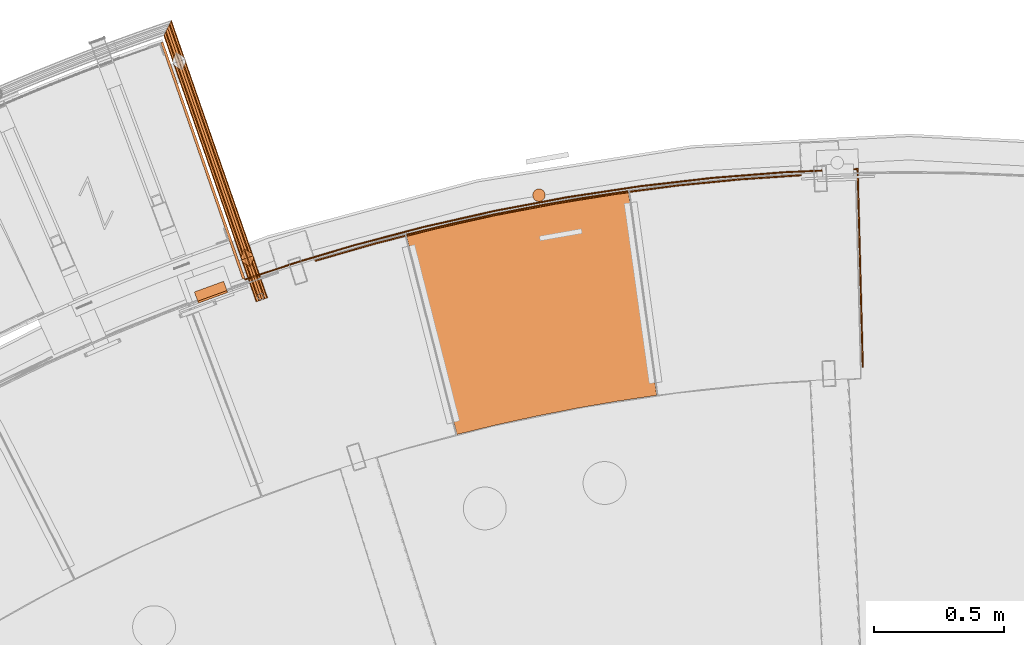
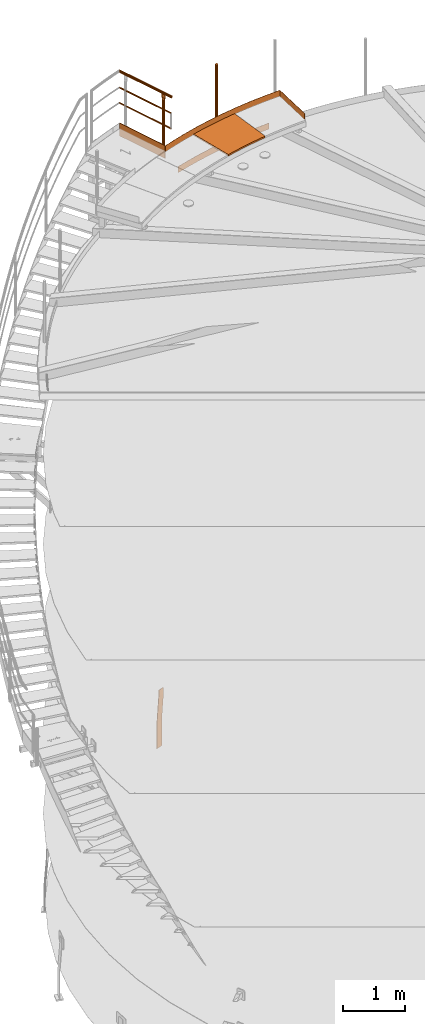
# One storey, part 39 of 126: 10 proxies.
"""IFC2X3 building model written with IfcOpenShell, lengths in millimetres."""

import ifcopenshell
import ifcopenshell.guid

model = None  # the IFC model being written
_history = None  # IfcOwnerHistory: only IFC2X3 demands one
_inside = {}  # id of a spatial element -> (the spatial element, [elements in it])
_under = {}  # id of a project, library or spatial element -> (it, [spatial elements below it])
_declared = {}  # id of a project -> (the project, [libraries it declares])
_typed = {}  # id of a type object -> (the type object, [elements of that type])
_made_of = {}  # id of a material, layer set ... -> (it, [elements and type objects made of it])


def new_model(schema):
    """Start an empty IFC model of exactly this schema.

    Asked for "IFC4X3", IfcOpenShell would pick the latest addendum, in which some entities
    have other attributes; the version numbers below select the first issue.
    IFC2X3 requires an IfcOwnerHistory on every rooted entity: one is made here for all.
    """
    global model, _history
    if schema == "IFC4X3":
        model = ifcopenshell.file(schema_version=(4, 3, 0, 0))
    else:
        model = ifcopenshell.file(schema=schema)
    _inside.clear()
    _under.clear()
    _declared.clear()
    _typed.clear()
    _made_of.clear()
    _history = None
    if model.schema == "IFC2X3":
        org = make("IfcOrganization", Name="unknown")
        user = make(
            "IfcPersonAndOrganization",
            ThePerson=make("IfcPerson", FamilyName="unknown"),
            TheOrganization=org,
        )
        app = make(
            "IfcApplication",
            ApplicationDeveloper=org,
            Version="unknown",
            ApplicationFullName="unknown",
            ApplicationIdentifier="unknown",
        )
        _history = make(
            "IfcOwnerHistory",
            OwningUser=user,
            OwningApplication=app,
            ChangeAction="ADDED",
            CreationDate=0,
        )
    return model


def make(cls, **values):
    """One entity of the class cls with the attributes given. An attribute that is None is left unset."""
    return model.create_entity(
        cls, **{name: value for name, value in values.items() if value is not None}
    )


def rooted(cls, **values):
    """An entity with a GlobalId (a new one), such as an element, a storey or a relation."""
    return make(cls, GlobalId=ifcopenshell.guid.new(), OwnerHistory=_history, **values)


def si_unit(unit_type, name, prefix=None):
    """IfcSIUnit, for example si_unit("LENGTHUNIT", "METRE", prefix="MILLI")."""
    return make("IfcSIUnit", UnitType=unit_type, Prefix=prefix, Name=name)


def assignment(units):
    """IfcUnitAssignment: the units of a project."""
    return None if units is None else make("IfcUnitAssignment", Units=units)


def point(xyz):
    """IfcCartesianPoint."""
    return None if xyz is None else make("IfcCartesianPoint", Coordinates=xyz)


def direction(xyz):
    """IfcDirection."""
    return None if xyz is None else make("IfcDirection", DirectionRatios=xyz)


def frame(location, z_axis=None, x_axis=None):
    """IfcAxis2Placement3D, a coordinate frame: its origin and axes. An axis left out is left unset."""
    return make(
        "IfcAxis2Placement3D",
        Location=point(location),
        Axis=direction(z_axis),
        RefDirection=direction(x_axis),
    )


def origin():
    """The frame at (0, 0, 0) with its axes left unset."""
    return frame((0.0, 0.0, 0.0))


def origin_with_axes():
    """The frame at (0, 0, 0) with the z axis (0, 0, 1) and the x axis (1, 0, 0) written out."""
    return frame((0.0, 0.0, 0.0), z_axis=(0.0, 0.0, 1.0), x_axis=(1.0, 0.0, 0.0))


def place(relative_to, where):
    """IfcLocalPlacement: puts the frame where relative to a parent placement (None: the world)."""
    return make(
        "IfcLocalPlacement", PlacementRelTo=relative_to, RelativePlacement=where
    )


def context(
    kind, dimensions, precision=None, world=None, true_north=None, identifier=None
):
    """IfcGeometricRepresentationContext, for example the 3D "Model" context."""
    return make(
        "IfcGeometricRepresentationContext",
        ContextIdentifier=identifier,
        ContextType=kind,
        CoordinateSpaceDimension=dimensions,
        Precision=precision,
        WorldCoordinateSystem=world,
        TrueNorth=true_north,
    )


def project(units=None, contexts=None):
    """IfcProject with its units and contexts."""
    return rooted(
        "IfcProject",
        Name="project",
        RepresentationContexts=contexts,
        UnitsInContext=assignment(units),
    )


def spatial(cls, under=None, at=None, **own):
    """A site, building, storey or space (cls), placed at a placement, below another one or the project."""
    s = rooted(cls, ObjectPlacement=at, **own)
    if under is not None:
        _under.setdefault(under.id(), (under, []))[1].append(s)
    return s


def faces_of(points, faces, orient=None, outer=None):
    """IfcFace entities. A face is a list of loops; a loop is a list of indices into points, from 0.

    orient and outer hold one flag for each loop. By default every Orientation is true, the
    first loop of a face is its IfcFaceOuterBound and the others are IfcFaceBound.
    """
    made = []
    for i, loops in enumerate(faces):
        bounds = []
        for j, loop in enumerate(loops):
            is_outer = j == 0 if outer is None else outer[i][j]
            bounds.append(
                make(
                    "IfcFaceOuterBound" if is_outer else "IfcFaceBound",
                    Bound=make("IfcPolyLoop", Polygon=[points[k] for k in loop]),
                    Orientation=True if orient is None else orient[i][j],
                )
            )
        made.append(make("IfcFace", Bounds=bounds))
    return made


def faceted_brep(points, faces, orient=None, outer=None, voids=None):
    """IfcFacetedBrep: a solid bounded by flat faces; with voids (closed shells), ...WithVoids."""
    shared = [point(p) for p in points]
    hull = make("IfcClosedShell", CfsFaces=faces_of(shared, faces, orient, outer))
    if voids is None:
        return make("IfcFacetedBrep", Outer=hull)
    return make(
        "IfcFacetedBrepWithVoids",
        Outer=hull,
        Voids=[
            make(cls, CfsFaces=faces_of(shared, fs, o, b)) for cls, fs, o, b in voids
        ],
    )


def shape(context_of_items, identifier, shape_type, items):
    """IfcShapeRepresentation: the items that make up one representation, for example the "Body"."""
    return make(
        "IfcShapeRepresentation",
        ContextOfItems=context_of_items,
        RepresentationIdentifier=identifier,
        RepresentationType=shape_type,
        Items=items,
    )


def material(Name=None, Category=None):
    """IfcMaterial."""
    return make("IfcMaterial", Name=Name, Category=Category)


def made_of(thing, what):
    """Note that an element or type object is made of a material, layer set ...; save() writes the relation."""
    if what is not None:
        _made_of.setdefault(what.id(), (what, []))[1].append(thing)
    return thing


def element(
    cls,
    number,
    at=None,
    inside=None,
    cuts=None,
    type_object=None,
    material=None,
    context=None,
    identifier="Body",
    shape_type=None,
    held_by="IfcProductDefinitionShape",
    body=None,
    shapes=None,
    **own,
):
    """One element of the class cls, such as IfcWall. Its Tag is "e" and its number.

    at: its placement. inside: the storey or other place that contains it. cuts: it is an
    opening in that element (IfcRelVoidsElement). A single representation is given by context,
    identifier, shape_type and body (its items); several are given by shapes. held_by: the class
    of the entity that holds the representations. save() writes the other relations.
    """
    e = rooted(cls, Tag="e%d" % number, ObjectPlacement=at, **own)
    if body is not None:
        shapes = [shape(context, identifier, shape_type, body)]
    if shapes is not None:
        e.Representation = make(held_by, Representations=shapes)
    if inside is not None:
        _inside.setdefault(inside.id(), (inside, []))[1].append(e)
    if cuts is not None:
        rooted(
            "IfcRelVoidsElement", RelatingBuildingElement=cuts, RelatedOpeningElement=e
        )
    if type_object is not None:
        _typed.setdefault(type_object.id(), (type_object, []))[1].append(e)
    return made_of(e, material)


def aggregate(whole, parts):
    """IfcRelAggregates: a whole, such as a stair, and the parts it consists of."""
    return rooted("IfcRelAggregates", RelatingObject=whole, RelatedObjects=parts)


def save(model, path):
    """Write the relations noted so far, then the file.

    IfcRelAggregates (storeys below a building ...), IfcRelContainedInSpatialStructure (elements
    in a storey), IfcRelDefinesByType, IfcRelAssociatesMaterial and IfcRelDeclares: one each for
    every whole, place, type object, material and project.
    """
    for whole, parts in _under.values():
        aggregate(whole, parts)
    for where, things in _inside.values():
        rooted(
            "IfcRelContainedInSpatialStructure",
            RelatedElements=things,
            RelatingStructure=where,
        )
    for kind, things in _typed.values():
        rooted("IfcRelDefinesByType", RelatedObjects=things, RelatingType=kind)
    for what, things in _made_of.values():
        rooted("IfcRelAssociatesMaterial", RelatedObjects=things, RelatingMaterial=what)
    for by, libraries in _declared.values():
        rooted("IfcRelDeclares", RelatingContext=by, RelatedDefinitions=libraries)
    model.write(path)


model = new_model("IFC2X3")

# Units and contexts
context_of_model_1 = context(None, 3, precision=0.1, world=origin())
context_of_model_2 = context(None, 3, precision=0.1, world=origin())
ifc_project = project(units=[si_unit("LENGTHUNIT", "METRE", prefix="MILLI"), si_unit("AREAUNIT", "SQUARE_METRE", prefix="CENTI"), si_unit("VOLUMEUNIT", "CUBIC_METRE", prefix="CENTI"), si_unit("MASSUNIT", "GRAM", prefix="KILO")], contexts=[context_of_model_1, context_of_model_2])

# Site, building, storey
site_placement = place(None, origin_with_axes())
site = spatial("IfcSite", under=ifc_project, at=site_placement, CompositionType="ELEMENT")
building_placement = place(site_placement, origin_with_axes())
building = spatial("IfcBuilding", under=site, at=building_placement, CompositionType="ELEMENT")
storey_placement = place(building_placement, origin_with_axes())
storey = spatial("IfcBuildingStorey", under=building, at=storey_placement, CompositionType="ELEMENT")

# Proxies
ifc_material_1 = material(Name="STAHL")
proxy_1_placement = place(storey_placement, origin_with_axes())
element("IfcBuildingElementProxy", 1, at=proxy_1_placement, inside=storey, material=ifc_material_1, Name="profile", context=context_of_model_2, shape_type="Brep", body=[
    faceted_brep([(5376.2, 15385.8, 654.1), (5379.0, 15378.3, 654.1), (5381.3, 15379.1, 651.1), (5378.6, 15386.7, 651.1), (5380.3, 15387.3, 647.7), (5383.0, 15379.8, 647.7), (5381.4, 15387.7, 643.9), (5384.1, 15380.2, 643.9), (5384.5, 15380.3, 640.0), (5384.5, 15380.3, 540.0), (5371.5, 15416.0, 0.0), (5371.5, 15416.0, -500.0), (5368.7, 15423.5, -500.0), (5368.7, 15423.5, 0.0), (5381.7, 15387.8, 540.0), (5381.7, 15387.8, 640.0), (5277.2, 15341.3, 654.1), (5274.5, 15348.8, 654.1), (5272.1, 15347.9, 651.1), (5274.9, 15340.4, 651.1), (5273.1, 15339.8, 647.7), (5270.4, 15347.3, 647.7), (5272.1, 15339.4, 643.9), (5269.3, 15346.9, 643.9), (5271.7, 15339.3, 640.0), (5269.0, 15346.8, 640.0), (5269.0, 15346.8, 540.0), (5256.0, 15382.5, 0.0), (5256.0, 15382.5, -500.0), (5258.7, 15375.0, -500.0), (5258.7, 15375.0, 0.0), (5271.7, 15339.3, 540.0), (5286.8, 15344.8, 659.6), (5290.5, 15346.1, 660.0), (5365.7, 15373.5, 660.0), (5369.3, 15374.8, 659.6), (5366.6, 15382.3, 659.6), (5362.9, 15381.0, 660.0), (5287.8, 15353.6, 660.0), (5284.1, 15352.3, 659.6), (5280.6, 15351.0, 658.5), (5283.3, 15343.5, 658.5), (5277.3, 15349.8, 656.6), (5280.1, 15342.3, 656.6), (5372.9, 15376.1, 658.5), (5370.1, 15383.6, 658.5), (5376.1, 15377.3, 656.6), (5373.4, 15384.8, 656.6)], [[[0, 1, 2, 3]], [[4, 3, 2, 5]], [[6, 4, 5, 7]], [[7, 8, 9, 10, 11, 12, 13, 14, 15, 6]], [[16, 17, 18, 19]], [[20, 19, 18, 21]], [[22, 20, 21, 23]], [[24, 22, 23, 25, 26, 27, 28, 29, 30, 31]], [[32, 33, 34, 35, 36, 37, 38, 39]], [[32, 39, 40, 41]], [[41, 40, 42, 43]], [[43, 42, 17, 16]], [[36, 35, 44, 45]], [[45, 44, 46, 47]], [[47, 46, 1, 0]], [[26, 25, 23, 21, 18, 17, 42, 40, 39, 38, 37, 36, 45, 47, 0, 3, 4, 6, 15, 14, 13, 12, 28, 27]], [[24, 31, 30, 29, 11, 10, 9, 8, 7, 5, 2, 1, 46, 44, 35, 34, 33, 32, 41, 43, 16, 19, 20, 22]], [[28, 12, 11, 29]]]),
])
proxy_2_placement = place(storey_placement, origin_with_axes())
element("IfcBuildingElementProxy", 2, at=proxy_2_placement, inside=storey, material=ifc_material_1, Name="profile", context=context_of_model_2, shape_type="Brep", body=[
    faceted_brep([(5449.7, 15432.7, 11065.2), (5449.7, 15432.7, 11185.2), (5658.4, 15501.3, 11185.2), (5868.9, 15564.0, 11185.2), (6140.0, 15635.4, 11185.2), (6413.5, 15697.1, 11185.2), (6689.0, 15749.0, 11185.2), (6966.2, 15791.0, 11185.2), (7244.8, 15823.1, 11185.2), (7524.3, 15845.3, 11185.2), (7804.4, 15857.4, 11185.2), (7809.4, 15857.6, 11185.2), (7809.4, 15857.6, 11065.2), (7804.4, 15857.4, 11065.2), (7524.3, 15845.3, 11065.2), (7244.8, 15823.1, 11065.2), (6966.2, 15791.0, 11065.2), (6689.0, 15749.0, 11065.2), (6413.5, 15697.1, 11065.2), (6140.0, 15635.4, 11065.2), (5868.9, 15564.0, 11065.2), (5658.3, 15501.3, 11065.2), (5451.3, 15428.0, 11185.2), (5451.3, 15428.0, 11065.2), (5659.5, 15496.4, 11065.2), (5869.6, 15559.0, 11065.2), (6140.7, 15630.4, 11065.2), (6414.1, 15692.1, 11065.2), (6689.5, 15744.0, 11065.2), (6966.6, 15786.0, 11065.2), (7245.1, 15818.1, 11065.2), (7524.5, 15840.3, 11065.2), (7804.5, 15852.4, 11065.2), (7804.5, 15852.4, 11185.2), (7524.5, 15840.3, 11185.2), (7245.1, 15818.1, 11185.2), (6966.6, 15786.0, 11185.2), (6689.5, 15744.0, 11185.2), (6414.1, 15692.1, 11185.2), (6140.7, 15630.4, 11185.2), (5869.6, 15559.0, 11185.2), (5659.5, 15496.4, 11185.2), (7829.4, 15093.7, 11185.2), (7829.4, 15093.7, 11065.2), (7824.4, 15093.6, 11065.2), (7824.4, 15093.6, 11185.2)], [[[0, 1, 2, 3, 4, 5, 6, 7, 8, 9, 10, 11, 12, 13, 14, 15, 16, 17, 18, 19, 20, 21]], [[22, 23, 24, 25, 26, 27, 28, 29, 30, 31, 32, 33, 34, 35, 36, 37, 38, 39, 40, 41]], [[22, 1, 0, 23]], [[12, 11, 42, 43]], [[44, 32, 31, 30, 29, 28, 27, 26, 25, 24, 23, 0, 21, 20, 19, 18, 17, 16, 15, 14, 13, 12, 43]], [[45, 42, 11, 10, 9, 8, 7, 6, 5, 4, 3, 2, 1, 22, 41, 40, 39, 38, 37, 36, 35, 34, 33]], [[32, 44, 45, 33]], [[45, 44, 43, 42]]]),
])
proxy_3_placement = place(storey_placement, origin_with_axes())
element("IfcBuildingElementProxy", 3, at=proxy_3_placement, inside=storey, material=ifc_material_1, Name="profile", context=context_of_model_2, shape_type="Brep", body=[
    faceted_brep([(6605.0, 15759.7, 12185.2), (6605.0, 15759.7, 10955.2), (6603.1, 15765.2, 10955.2), (6603.1, 15765.2, 12185.2), (6599.9, 15770.0, 10955.2), (6599.9, 15770.0, 12185.2), (6595.7, 15774.0, 10955.2), (6595.7, 15774.0, 12185.2), (6590.6, 15776.8, 10955.2), (6590.6, 15776.8, 12185.2), (6585.0, 15778.4, 10955.2), (6585.0, 15778.4, 12185.2), (6579.1, 15778.5, 10955.2), (6579.1, 15778.5, 12185.2), (6573.4, 15777.3, 10955.2), (6573.4, 15777.3, 12185.2), (6568.2, 15774.7, 10955.2), (6568.2, 15774.7, 12185.2), (6563.8, 15770.9, 10955.2), (6563.8, 15770.9, 12185.2), (6560.3, 15766.2, 10955.2), (6560.3, 15766.2, 12185.2), (6558.1, 15760.9, 10955.2), (6558.1, 15760.9, 12185.2), (6557.3, 15755.1, 10955.2), (6557.3, 15755.1, 12185.2), (6557.9, 15749.3, 12185.2), (6557.9, 15749.3, 10955.2), (6559.8, 15743.8, 10955.2), (6559.8, 15743.8, 12185.2), (6563.0, 15738.9, 10955.2), (6563.0, 15738.9, 12185.2), (6567.2, 15735.0, 10955.2), (6567.2, 15735.0, 12185.2), (6572.3, 15732.1, 10955.2), (6572.3, 15732.1, 12185.2), (6577.9, 15730.6, 10955.2), (6577.9, 15730.6, 12185.2), (6583.7, 15730.4, 10955.2), (6583.7, 15730.4, 12185.2), (6589.4, 15731.7, 10955.2), (6589.4, 15731.7, 12185.2), (6594.7, 15734.3, 10955.2), (6594.7, 15734.3, 12185.2), (6599.1, 15738.0, 10955.2), (6599.1, 15738.0, 12185.2), (6602.5, 15742.7, 10955.2), (6602.5, 15742.7, 12185.2), (6604.7, 15748.1, 10955.2), (6604.7, 15748.1, 12185.2), (6605.6, 15753.9, 10955.2), (6605.6, 15753.9, 12185.2)], [[[0, 1, 2, 3]], [[3, 2, 4, 5]], [[5, 4, 6, 7]], [[7, 6, 8, 9]], [[9, 8, 10, 11]], [[11, 10, 12, 13]], [[13, 12, 14, 15]], [[15, 14, 16, 17]], [[17, 16, 18, 19]], [[19, 18, 20, 21]], [[21, 20, 22, 23]], [[23, 22, 24, 25]], [[26, 25, 24, 27]], [[26, 27, 28, 29]], [[29, 28, 30, 31]], [[31, 30, 32, 33]], [[33, 32, 34, 35]], [[35, 34, 36, 37]], [[37, 36, 38, 39]], [[39, 38, 40, 41]], [[41, 40, 42, 43]], [[43, 42, 44, 45]], [[45, 44, 46, 47]], [[47, 46, 48, 49]], [[49, 48, 50, 51]], [[51, 50, 1, 0]], [[39, 41, 43, 45, 47, 49, 51, 0, 3, 5, 7, 9, 11, 13, 15, 17, 19, 21, 23, 25, 26, 29, 31, 33, 35, 37]], [[38, 36, 34, 32, 30, 28, 27, 24, 22, 20, 18, 16, 14, 12, 10, 8, 6, 4, 2, 1, 50, 48, 46, 44, 42, 40]]]),
])
proxy_4_placement = place(storey_placement, origin_with_axes())
element("IfcBuildingElementProxy", 4, at=proxy_4_placement, inside=storey, material=ifc_material_1, Name="profile", context=context_of_model_2, shape_type="Brep", body=[
    faceted_brep([(5719.6, 15504.4, 10516.0), (5719.6, 15504.4, 10636.0), (5948.3, 15570.3, 10636.0), (6178.8, 15629.2, 10636.0), (6410.9, 15681.1, 10636.0), (6644.6, 15725.9, 10636.0), (6879.5, 15763.6, 10636.0), (7115.5, 15794.2, 10636.0), (7352.2, 15817.6, 10636.0), (7589.6, 15833.8, 10636.0), (7589.6, 15833.8, 10516.0), (7352.2, 15817.6, 10516.0), (7115.5, 15794.2, 10516.0), (6879.5, 15763.6, 10516.0), (6644.6, 15725.9, 10516.0), (6410.9, 15681.1, 10516.0), (6178.8, 15629.2, 10516.0), (5948.3, 15570.3, 10516.0), (5721.1, 15499.6, 10636.0), (5949.6, 15565.4, 10636.0), (6179.9, 15624.3, 10636.0), (6412.0, 15676.2, 10636.0), (6645.5, 15721.0, 10636.0), (6880.2, 15758.7, 10636.0), (7116.0, 15789.3, 10636.0), (7352.6, 15812.6, 10636.0), (7589.9, 15828.8, 10636.0), (5721.1, 15499.6, 10516.0), (5949.6, 15565.4, 10516.0), (6179.9, 15624.3, 10516.0), (6412.0, 15676.2, 10516.0), (6645.5, 15721.0, 10516.0), (6880.2, 15758.7, 10516.0), (7116.0, 15789.3, 10516.0), (7352.6, 15812.6, 10516.0), (7589.9, 15828.8, 10516.0)], [[[0, 1, 2, 3, 4, 5, 6, 7, 8, 9, 10, 11, 12, 13, 14, 15, 16, 17]], [[18, 19, 20, 21, 22, 23, 24, 25, 26, 9, 8, 7, 6, 5, 4, 3, 2, 1]], [[18, 27, 28, 29, 30, 31, 32, 33, 34, 35, 26, 25, 24, 23, 22, 21, 20, 19]], [[27, 0, 17, 16, 15, 14, 13, 12, 11, 10, 35, 34, 33, 32, 31, 30, 29, 28]], [[18, 1, 0, 27]], [[26, 35, 10, 9]]]),
])
proxy_5_placement = place(storey_placement, origin_with_axes())
element("IfcBuildingElementProxy", 5, at=proxy_5_placement, inside=storey, material=ifc_material_1, Name="profile", context=context_of_model_2, shape_type="Brep", body=[
    faceted_brep([(6266.3, 14834.1, 11085.2), (6266.3, 14834.1, 11055.2), (6418.5, 14871.1, 11055.2), (6571.5, 14904.7, 11055.2), (6725.2, 14934.8, 11055.2), (6879.6, 14961.6, 11055.2), (7034.4, 14984.8, 11055.2), (7034.4, 14984.8, 11085.2), (6879.6, 14961.6, 11085.2), (6725.2, 14934.8, 11085.2), (6571.5, 14904.7, 11085.2), (6418.5, 14871.1, 11085.2), (6069.7, 15605.5, 11085.2), (6069.7, 15605.5, 11055.2), (6239.2, 15646.6, 11085.2), (6409.6, 15684.0, 11085.2), (6580.7, 15717.6, 11085.2), (6752.6, 15747.4, 11085.2), (6925.0, 15773.3, 11085.2), (6925.0, 15773.3, 11055.2), (6752.6, 15747.4, 11055.2), (6580.7, 15717.6, 11055.2), (6409.6, 15684.0, 11055.2), (6239.2, 15646.6, 11055.2)], [[[0, 1, 2, 3, 4, 5, 6, 7, 8, 9, 10, 11]], [[0, 12, 13, 1]], [[13, 12, 14, 15, 16, 17, 18, 19, 20, 21, 22, 23]], [[18, 7, 6, 19]], [[0, 11, 10, 9, 8, 7, 18, 17, 16, 15, 14, 12]], [[1, 13, 23, 22, 21, 20, 19, 6, 5, 4, 3, 2]]]),
])
ifc_material_2 = material(Name="S235JRG2")
proxy_6_placement = place(storey_placement, origin_with_axes())
element("IfcBuildingElementProxy", 6, at=proxy_6_placement, inside=storey, material=ifc_material_2, Name="HANDLAUF", context=context_of_model_2, shape_type="Brep", body=[
    faceted_brep([(5441.3961, 15431.77, 11185.0), (5450.8425, 15435.051, 11185.0), (5135.6196, 16344.237, 11185.0), (5126.1495, 16341.025, 11185.0), (5450.8425, 15435.051, 10935.0), (5135.6196, 16344.237, 10935.0), (5441.3961, 15431.77, 10935.0), (5126.1495, 16341.025, 10935.0)], [[[0, 1, 2, 3]], [[1, 4, 5, 2]], [[4, 6, 7, 5]], [[0, 3, 7, 6]], [[0, 6, 4, 1]], [[2, 5, 7, 3]]]),
])
proxy_7_placement = place(storey_placement, origin_with_axes())
element("IfcBuildingElementProxy", 7, at=proxy_7_placement, inside=storey, material=ifc_material_2, Name="HANDLAUF", context=context_of_model_2, shape_type="Brep", body=[
    faceted_brep([(5504.4573, 15347.8, 12181.764), (5515.8661, 15351.755, 12185.0), (5153.1873, 16397.817, 12185.0), (5145.6923, 16382.573, 12181.764), (5140.2055, 16371.414, 12172.925), (5496.1055, 15344.904, 12172.925), (5138.1972, 16367.33, 12160.85), (5493.0486, 15343.844, 12160.85), (5140.2055, 16371.414, 12148.775), (5496.1055, 15344.904, 12148.775), (5145.6923, 16382.573, 12139.936), (5504.4573, 15347.8, 12139.936), (5153.1873, 16397.817, 12136.7), (5515.8661, 15351.755, 12136.7), (5160.6823, 16413.061, 12139.936), (5527.2748, 15355.711, 12139.936), (5166.1691, 16424.22, 12148.775), (5535.6266, 15358.607, 12148.775), (5168.1774, 16428.304, 12160.85), (5538.6836, 15359.666, 12160.85), (5166.1691, 16424.22, 12172.925), (5535.6266, 15358.607, 12172.925), (5160.6823, 16413.061, 12181.764), (5527.2748, 15355.711, 12181.764), (5526.0938, 15355.302, 12179.599), (5515.8661, 15351.755, 12182.5), (5153.1873, 16397.817, 12182.5), (5159.9065, 16411.483, 12179.599), (5164.8252, 16421.487, 12171.675), (5533.581, 15357.897, 12171.675), (5166.6256, 16425.148, 12160.85), (5536.3215, 15358.848, 12160.85), (5164.8252, 16421.487, 12150.025), (5533.581, 15357.897, 12150.025), (5159.9065, 16411.483, 12142.101), (5526.0938, 15355.302, 12142.101), (5153.1873, 16397.817, 12139.2), (5515.8661, 15351.755, 12139.2), (5146.4682, 16384.151, 12142.101), (5505.6384, 15348.21, 12142.101), (5141.5494, 16374.147, 12150.025), (5498.1511, 15345.614, 12150.025), (5139.749, 16370.486, 12160.85), (5495.4106, 15344.663, 12160.85), (5141.5494, 16374.147, 12171.675), (5498.1511, 15345.614, 12171.675), (5146.4682, 16384.151, 12179.599), (5505.6384, 15348.21, 12179.599)], [[[0, 1, 2, 3]], [[0, 3, 4, 5]], [[5, 4, 6, 7]], [[7, 6, 8, 9]], [[9, 8, 10, 11]], [[11, 10, 12, 13]], [[13, 12, 14, 15]], [[15, 14, 16, 17]], [[17, 16, 18, 19]], [[19, 18, 20, 21]], [[21, 20, 22, 23]], [[1, 23, 22, 2]], [[24, 25, 26, 27]], [[24, 27, 28, 29]], [[29, 28, 30, 31]], [[31, 30, 32, 33]], [[33, 32, 34, 35]], [[35, 34, 36, 37]], [[37, 36, 38, 39]], [[39, 38, 40, 41]], [[41, 40, 42, 43]], [[43, 42, 44, 45]], [[45, 44, 46, 47]], [[25, 47, 46, 26]], [[7, 9, 11, 13, 15, 17, 19, 21, 23, 1, 0, 5], [24, 29, 31, 33, 35, 37, 39, 41, 43, 45, 47, 25]], [[18, 16, 14, 12, 10, 8, 6, 4, 3, 2, 22, 20], [26, 46, 44, 42, 40, 38, 36, 34, 32, 30, 28, 27]]]),
])
proxy_8_placement = place(storey_placement, origin_with_axes())
element("IfcBuildingElementProxy", 8, at=proxy_8_placement, inside=storey, material=ifc_material_2, context=context_of_model_2, shape_type="Brep", body=[
    faceted_brep([(5505.5898, 15352.362, 11847.666), (5515.8661, 15351.755, 11851.605), (5153.1873, 16397.817, 11851.605), (5147.284, 16385.811, 11847.666), (5144.8388, 16380.838, 11838.155), (5498.7523, 15360.057, 11838.155), (5147.284, 16385.811, 11828.645), (5499.3588, 15370.334, 11828.645), (5153.1873, 16397.817, 11824.705), (5507.0542, 15377.171, 11824.705), (5159.0906, 16409.823, 11828.645), (5517.3305, 15376.565, 11828.645), (5161.5358, 16414.797, 11838.155), (5524.168, 15368.869, 11838.155), (5159.0906, 16409.823, 11847.666), (5523.5614, 15358.593, 11847.666), (5521.762, 15359.466, 11846.252), (5515.2109, 15353.645, 11849.605), (5153.1873, 16397.817, 11849.605), (5158.2128, 16408.038, 11846.252), (5160.2944, 16412.272, 11838.155), (5522.2784, 15368.214, 11838.155), (5158.2128, 16408.038, 11830.059), (5516.4576, 15374.765, 11830.059), (5153.1873, 16397.817, 11826.705), (5507.7094, 15375.282, 11826.705), (5148.1618, 16387.596, 11830.059), (5501.1583, 15369.461, 11830.059), (5146.0802, 16383.362, 11838.155), (5500.6419, 15360.713, 11838.155), (5148.1618, 16387.596, 11846.252), (5506.4627, 15354.162, 11846.252)], [[[0, 1, 2, 3]], [[0, 3, 4, 5]], [[5, 4, 6, 7]], [[7, 6, 8, 9]], [[9, 8, 10, 11]], [[11, 10, 12, 13]], [[13, 12, 14, 15]], [[1, 15, 14, 2]], [[16, 17, 18, 19]], [[16, 19, 20, 21]], [[21, 20, 22, 23]], [[23, 22, 24, 25]], [[25, 24, 26, 27]], [[27, 26, 28, 29]], [[29, 28, 30, 31]], [[17, 31, 30, 18]], [[5, 7, 9, 11, 13, 15, 1, 0], [16, 21, 23, 25, 27, 29, 31, 17]], [[12, 10, 8, 6, 4, 3, 2, 14], [18, 30, 28, 26, 24, 22, 20, 19]]]),
])
proxy_9_placement = place(storey_placement, origin_with_axes())
element("IfcBuildingElementProxy", 9, at=proxy_9_placement, inside=storey, material=ifc_material_2, context=context_of_model_2, shape_type="Brep", body=[
    faceted_brep([(5499.3589, 15370.334, 11547.666), (5507.0543, 15377.171, 11551.605), (5153.1873, 16397.817, 11551.605), (5147.284, 16385.811, 11547.666), (5144.8388, 16380.838, 11538.155), (5498.7523, 15360.057, 11538.155), (5147.284, 16385.811, 11528.645), (5505.5898, 15352.362, 11528.645), (5153.1873, 16397.817, 11524.705), (5515.866, 15351.756, 11524.705), (5159.0906, 16409.823, 11528.645), (5523.5614, 15358.593, 11528.645), (5161.5358, 16414.797, 11538.155), (5524.168, 15368.869, 11538.155), (5159.0906, 16409.823, 11547.666), (5517.3306, 15376.565, 11547.666), (5516.4576, 15374.765, 11546.251), (5507.7094, 15375.281, 11549.605), (5153.1873, 16397.817, 11549.605), (5158.2128, 16408.038, 11546.251), (5160.2944, 16412.272, 11538.155), (5522.2784, 15368.214, 11538.155), (5158.2128, 16408.038, 11530.059), (5521.762, 15359.466, 11530.059), (5153.1873, 16397.817, 11526.705), (5515.2109, 15353.645, 11526.705), (5148.1618, 16387.596, 11530.059), (5506.4627, 15354.162, 11530.059), (5146.0802, 16383.362, 11538.155), (5500.6419, 15360.713, 11538.155), (5148.1618, 16387.596, 11546.251), (5501.1583, 15369.461, 11546.251)], [[[0, 1, 2, 3]], [[0, 3, 4, 5]], [[5, 4, 6, 7]], [[7, 6, 8, 9]], [[9, 8, 10, 11]], [[11, 10, 12, 13]], [[13, 12, 14, 15]], [[1, 15, 14, 2]], [[16, 17, 18, 19]], [[16, 19, 20, 21]], [[21, 20, 22, 23]], [[23, 22, 24, 25]], [[25, 24, 26, 27]], [[27, 26, 28, 29]], [[29, 28, 30, 31]], [[17, 31, 30, 18]], [[5, 7, 9, 11, 13, 15, 1, 0], [16, 21, 23, 25, 27, 29, 31, 17]], [[12, 10, 8, 6, 4, 3, 2, 14], [18, 30, 28, 26, 24, 22, 20, 19]]]),
])
ifc_material_3 = material(Name="1.4462")
proxy_10_placement = place(storey_placement, origin_with_axes())
element("IfcBuildingElementProxy", 10, at=proxy_10_placement, inside=storey, material=ifc_material_3, Name="Pfosten", context=context_of_model_2, shape_type="Brep", body=[
    faceted_brep([(5467.701, 15490.677, 12013.55), (5455.2323, 15489.778, 12013.55), (5455.2323, 15489.778, 11086.694), (5467.701, 15490.677, 11086.693), (5443.9849, 15495.234, 12013.55), (5443.9849, 15495.234, 11086.696), (5436.9724, 15505.583, 12013.55), (5436.9724, 15505.583, 11086.7), (5436.0739, 15518.052, 12013.55), (5436.0739, 15518.052, 11086.704), (5441.53, 15529.299, 12013.55), (5441.53, 15529.299, 11086.706), (5451.8789, 15536.312, 12013.55), (5451.8789, 15536.312, 11086.707), (5464.3475, 15537.21, 12013.55), (5464.3475, 15537.21, 11086.706), (5475.5949, 15531.754, 12013.55), (5475.5949, 15531.754, 11086.704), (5482.6074, 15521.405, 12013.55), (5482.6074, 15521.405, 11086.7), (5483.506, 15508.936, 12013.55), (5483.506, 15508.936, 11086.696), (5478.0498, 15497.689, 12013.55), (5478.0498, 15497.689, 11086.694), (5473.9588, 15529.864, 12013.55), (5463.8757, 15534.755, 12013.55), (5463.8757, 15534.755, 11086.706), (5473.9588, 15529.864, 11086.703), (5452.6978, 15533.949, 12013.55), (5452.6978, 15533.949, 11086.707), (5443.4203, 15527.663, 12013.55), (5443.4203, 15527.663, 11086.706), (5438.529, 15517.58, 12013.55), (5438.529, 15517.58, 11086.703), (5439.3345, 15506.402, 12013.55), (5439.3345, 15506.402, 11086.7), (5445.621, 15497.124, 12013.55), (5445.621, 15497.124, 11086.697), (5455.7041, 15492.233, 12013.55), (5455.7041, 15492.233, 11086.694), (5466.882, 15493.039, 12013.55), (5466.882, 15493.039, 11086.693), (5476.1596, 15499.325, 12013.55), (5476.1596, 15499.325, 11086.694), (5481.0509, 15509.408, 12013.55), (5481.0509, 15509.408, 11086.697), (5480.2454, 15520.586, 12013.55), (5480.2454, 15520.586, 11086.7), (5471.7491, 15479.001, 12061.85), (5469.839, 15479.113, 12061.85), (5468.5681, 15480.544, 12061.85), (5457.4279, 15512.675, 12061.85), (5446.2877, 15544.806, 12061.85), (5446.4004, 15546.716, 12061.85), (5447.8308, 15547.987, 12061.85), (5449.7409, 15547.875, 12061.85), (5451.0118, 15546.444, 12061.85), (5462.152, 15514.313, 12061.85), (5473.2922, 15482.182, 12061.85), (5473.1794, 15480.272, 12061.85), (5448.8387, 15545.691, 12061.85), (5448.737, 15545.805, 12061.85), (5448.5842, 15545.814, 12061.85), (5448.4698, 15545.713, 12061.85), (5448.4607, 15545.56, 12061.85), (5459.601, 15513.428, 12061.85), (5470.7412, 15481.297, 12061.85), (5470.8428, 15481.183, 12061.85), (5470.9957, 15481.174, 12061.85), (5471.1101, 15481.275, 12061.85), (5471.1191, 15481.428, 12061.85), (5459.9789, 15513.559, 12061.85), (5471.7491, 15479.001, 12136.7), (5469.839, 15479.113, 12136.7), (5468.5681, 15480.544, 12136.7), (5457.4279, 15512.675, 12136.7), (5446.2877, 15544.806, 12136.7), (5446.4004, 15546.716, 12136.7), (5447.8308, 15547.987, 12136.7), (5449.7409, 15547.875, 12136.7), (5451.0118, 15546.444, 12136.7), (5462.152, 15514.313, 12136.7), (5473.2922, 15482.182, 12136.7), (5473.1794, 15480.272, 12136.7), (5448.8387, 15545.691, 12136.7), (5448.737, 15545.805, 12136.7), (5448.5842, 15545.814, 12136.7), (5448.4698, 15545.713, 12136.7), (5448.4607, 15545.56, 12136.7), (5459.601, 15513.428, 12136.7), (5470.7412, 15481.297, 12136.7), (5470.8428, 15481.183, 12136.7), (5470.9957, 15481.174, 12136.7), (5471.1101, 15481.275, 12136.7), (5471.1191, 15481.428, 12136.7), (5459.9789, 15513.559, 12136.7)], [[[0, 1, 2, 3]], [[1, 4, 5, 2]], [[4, 6, 7, 5]], [[6, 8, 9, 7]], [[8, 10, 11, 9]], [[10, 12, 13, 11]], [[12, 14, 15, 13]], [[14, 16, 17, 15]], [[16, 18, 19, 17]], [[18, 20, 21, 19]], [[20, 22, 23, 21]], [[0, 3, 23, 22]], [[24, 25, 26, 27]], [[25, 28, 29, 26]], [[28, 30, 31, 29]], [[30, 32, 33, 31]], [[32, 34, 35, 33]], [[34, 36, 37, 35]], [[36, 38, 39, 37]], [[38, 40, 41, 39]], [[40, 42, 43, 41]], [[42, 44, 45, 43]], [[44, 46, 47, 45]], [[24, 27, 47, 46]], [[0, 48, 49, 1]], [[1, 49, 50, 4]], [[4, 50, 51, 6]], [[6, 51, 52, 8]], [[8, 52, 53, 10]], [[10, 53, 54, 12]], [[12, 54, 55, 14]], [[14, 55, 56, 16]], [[16, 56, 57, 18]], [[18, 57, 58, 20]], [[20, 58, 59, 22]], [[22, 59, 48, 0]], [[24, 60, 61, 25]], [[25, 61, 62, 28]], [[28, 62, 63, 30]], [[30, 63, 64, 32]], [[32, 64, 65, 34]], [[34, 65, 66, 36]], [[36, 66, 67, 38]], [[38, 67, 68, 40]], [[40, 68, 69, 42]], [[42, 69, 70, 44]], [[44, 70, 71, 46]], [[46, 71, 60, 24]], [[48, 72, 73, 49]], [[49, 73, 74, 50]], [[50, 74, 75, 51]], [[51, 75, 76, 52]], [[52, 76, 77, 53]], [[53, 77, 78, 54]], [[54, 78, 79, 55]], [[55, 79, 80, 56]], [[56, 80, 81, 57]], [[57, 81, 82, 58]], [[58, 82, 83, 59]], [[48, 59, 83, 72]], [[60, 84, 85, 61]], [[61, 85, 86, 62]], [[62, 86, 87, 63]], [[63, 87, 88, 64]], [[64, 88, 89, 65]], [[65, 89, 90, 66]], [[66, 90, 91, 67]], [[67, 91, 92, 68]], [[68, 92, 93, 69]], [[69, 93, 94, 70]], [[70, 94, 95, 71]], [[60, 71, 95, 84]], [[76, 75, 74, 73, 72, 83, 82, 81, 80, 79, 78, 77], [84, 95, 94, 93, 92, 91, 90, 89, 88, 87, 86, 85]], [[7, 9, 11, 13, 15, 17, 19, 21, 23, 3, 2, 5], [26, 29, 31, 33, 35, 37, 39, 41, 43, 45, 47, 27]]]),
])

save(model, "model.ifc")
